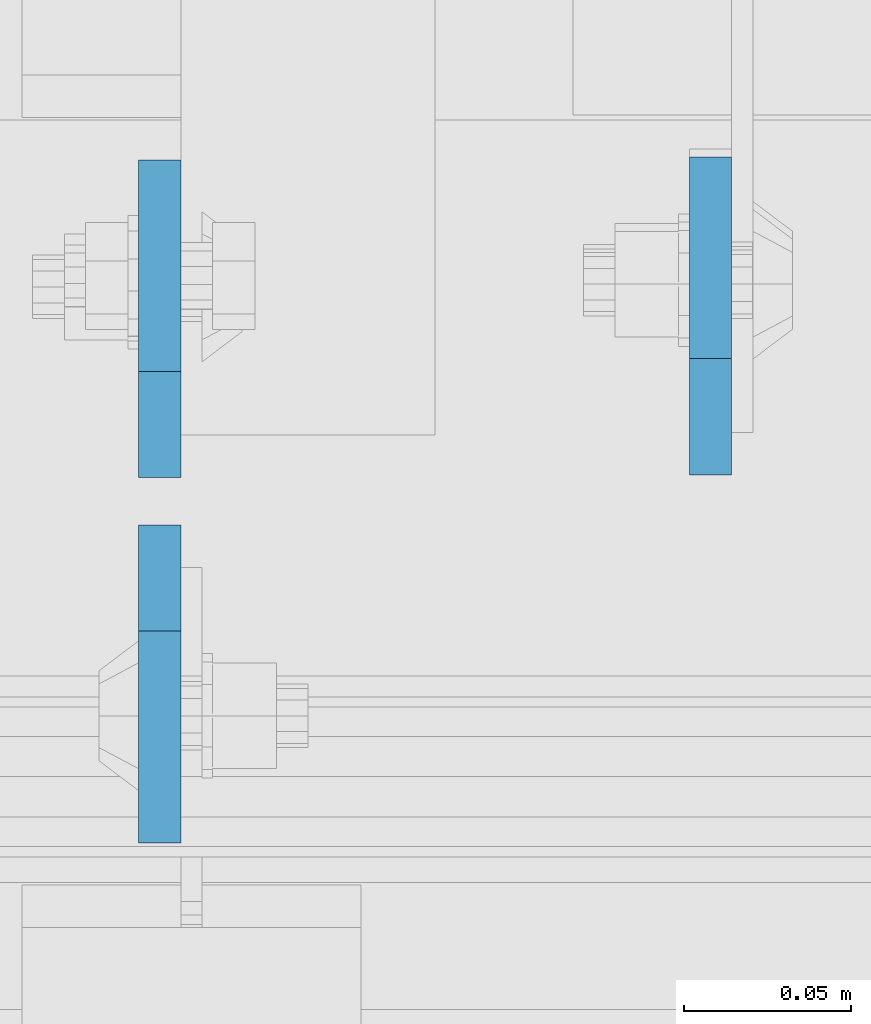
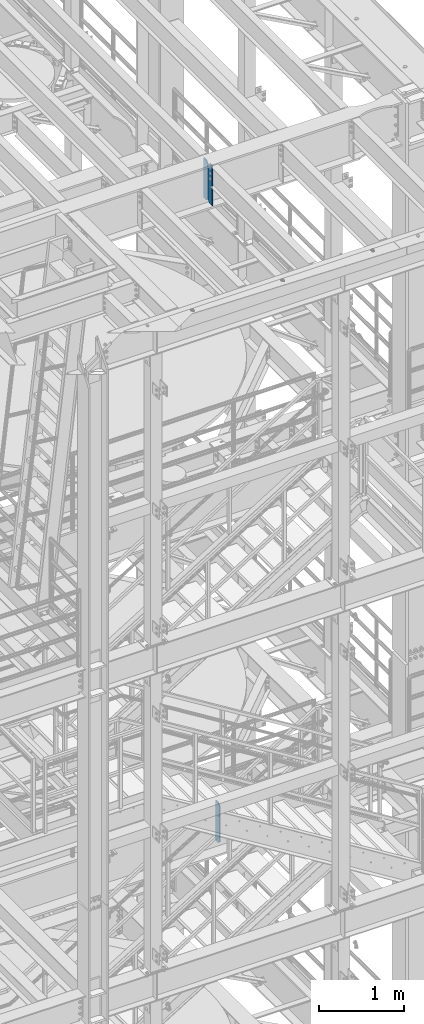
# One storey, part 1497 of 1876: 3 plates, 2 elements without a shape of their own.
"""IFC2X3 building model written with IfcOpenShell, lengths in millimetres."""

from ifc_helpers import new_model, si_unit, frame, origin_with_axes, place, context, subcontext, project, spatial, faceted_brep, material, type_object, element, aggregate, save


model = new_model("IFC2X3")

# Units and contexts
model_context = context("Model", 3, precision=1e-05, world=origin_with_axes())
body_context = subcontext(model_context, "Body", "Model", "MODEL_VIEW")
ifc_project = project(units=[si_unit("LENGTHUNIT", "METRE", prefix="MILLI"), si_unit("AREAUNIT", "SQUARE_METRE"), si_unit("VOLUMEUNIT", "CUBIC_METRE"), si_unit("MASSUNIT", "GRAM", prefix="KILO"), si_unit("TIMEUNIT", "SECOND"), si_unit("PLANEANGLEUNIT", "RADIAN"), si_unit("SOLIDANGLEUNIT", "STERADIAN"), si_unit("THERMODYNAMICTEMPERATUREUNIT", "DEGREE_CELSIUS"), si_unit("LUMINOUSINTENSITYUNIT", "LUMEN")], contexts=[model_context])

# Site, building, storey
site_placement = place(None, origin_with_axes())
site = spatial("IfcSite", under=ifc_project, at=site_placement, CompositionType="ELEMENT")
building_placement = place(site_placement, origin_with_axes())
building = spatial("IfcBuilding", under=site, at=building_placement, Name="Undefined", CompositionType="ELEMENT")
storey_placement = place(building_placement, origin_with_axes())
storey = spatial("IfcBuildingStorey", under=building, at=storey_placement, Name="Undefined", CompositionType="ELEMENT", Elevation=0.0)

# Assembly, plate
assembly_1_placement = place(storey_placement, origin_with_axes())
assembly_1 = element("IfcElementAssembly", 1, at=assembly_1_placement, inside=storey, Name="BEAM", AssemblyPlace="NOTDEFINED", PredefinedType="RIGID_FRAME")
ifc_material = material(Name="STEEL/A36")
plate_type = type_object("IfcPlateType", PredefinedType="NOTDEFINED")
plate_1_placement = place(assembly_1_placement, frame((4918.07499990463, -4564.0625, 12709.525), z_axis=(0.0, 0.0, 1.0), x_axis=(0.0, 1.0, 0.0)))
plate_1 = element("IfcPlate", 2, at=plate_1_placement, type_object=plate_type, material=ifc_material, Name="PLATE", context=body_context, shape_type="Brep", body=[
    faceted_brep([(0.0, -6.34999999999991, 34.9249992370605), (0.0, -6.35000000000036, 538.162475585938), (0.0, 6.35000000000036, 538.162475585938), (0.0, 6.34999999999991, 34.9249992370605), (34.9249992370605, -6.34999999999991, 573.087524414062), (34.9249992370605, 6.34999999999991, 573.087524414062), (95.25, -6.34999999999991, 573.087524414062), (95.25, 6.34999999999991, 573.087524414062), (95.25, -6.35000000000036, 0.0), (95.25, 6.35000000000036, 0.0), (34.9249992370605, -6.34999999999991, 0.0), (34.9249992370605, 6.34999999999991, 0.0)], [[[0, 1, 2, 3]], [[1, 4, 5, 2]], [[4, 6, 7, 5]], [[6, 8, 9, 7]], [[8, 10, 11, 9]], [[10, 0, 3, 11]], [[5, 7, 9, 11, 3, 2]], [[10, 8, 6, 4, 1, 0]]]),
])
aggregate(assembly_1, [plate_1])

# Assembly, plates
assembly_2_placement = place(storey_placement, origin_with_axes())
assembly_2 = element("IfcElementAssembly", 3, at=assembly_2_placement, inside=storey, Name="BEAM", AssemblyPlace="NOTDEFINED", PredefinedType="RIGID_FRAME")
plate_2_placement = place(assembly_2_placement, frame((4752.97499990463, -4579.14375, 21959.8875), z_axis=(0.0, 0.0, 1.0), x_axis=(0.0, -1.0, 0.0)))
plate_2 = element("IfcPlate", 4, at=plate_2_placement, type_object=plate_type, material=ifc_material, Name="PLATE", context=body_context, shape_type="Brep", body=[
    faceted_brep([(0.0, -6.34999999999991, 31.75), (0.0, -6.35000000000036, 538.162475585938), (0.0, 6.35000000000036, 538.162475585938), (0.0, 6.34999999999991, 31.75), (31.75, -6.35000000000036, 569.912475585938), (31.75, 6.35000000000036, 569.912475585938), (95.25, -6.35000000000036, 569.912475585938), (95.25, 6.35000000000036, 569.912475585938), (95.25, -6.35000000000036, 0.0), (95.25, 6.35000000000036, 0.0), (31.75, -6.34999999999991, 0.0), (31.75, 6.34999999999991, 0.0)], [[[0, 1, 2, 3]], [[1, 4, 5, 2]], [[4, 6, 7, 5]], [[6, 8, 9, 7]], [[8, 10, 11, 9]], [[10, 0, 3, 11]], [[5, 7, 9, 11, 3, 2]], [[10, 8, 6, 4, 1, 0]]]),
])
plate_3_placement = place(assembly_2_placement, frame((4752.97499990463, -4564.85625, 21959.8875), z_axis=(0.0, 0.0, 1.0), x_axis=(0.0, 1.0, 0.0)))
plate_3 = element("IfcPlate", 5, at=plate_3_placement, type_object=plate_type, material=ifc_material, Name="PLATE", context=body_context, shape_type="Brep", body=[
    faceted_brep([(0.0, -6.34999999999991, 31.75), (0.0, -6.35000000000036, 538.162475585938), (0.0, 6.35000000000036, 538.162475585938), (0.0, 6.34999999999991, 31.75), (31.75, -6.35000000000036, 569.912475585938), (31.75, 6.35000000000036, 569.912475585938), (95.25, -6.35000000000036, 569.912475585938), (95.25, 6.35000000000036, 569.912475585938), (95.25, -6.35000000000036, 0.0), (95.25, 6.35000000000036, 0.0), (31.75, -6.34999999999991, 0.0), (31.75, 6.34999999999991, 0.0)], [[[0, 1, 2, 3]], [[1, 4, 5, 2]], [[4, 6, 7, 5]], [[6, 8, 9, 7]], [[8, 10, 11, 9]], [[10, 0, 3, 11]], [[5, 7, 9, 11, 3, 2]], [[10, 8, 6, 4, 1, 0]]]),
])
aggregate(assembly_2, [plate_2, plate_3])

save(model, "model.ifc")
